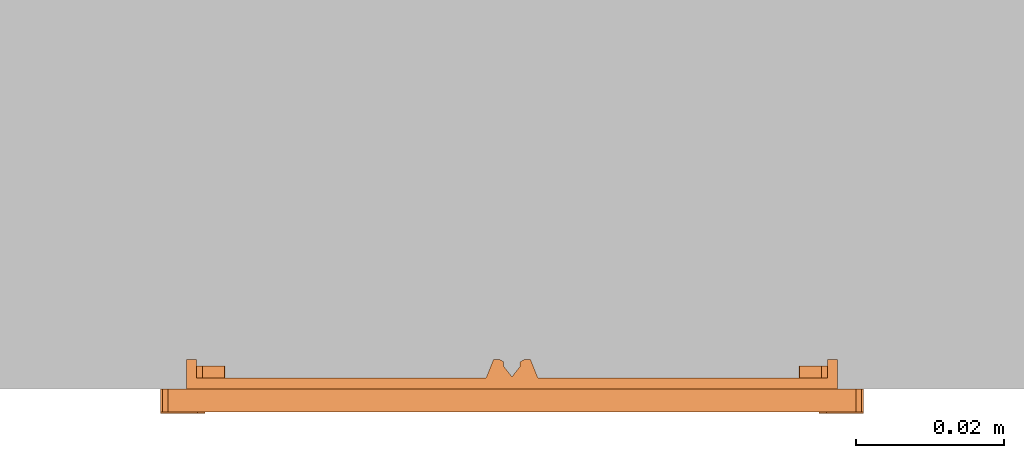
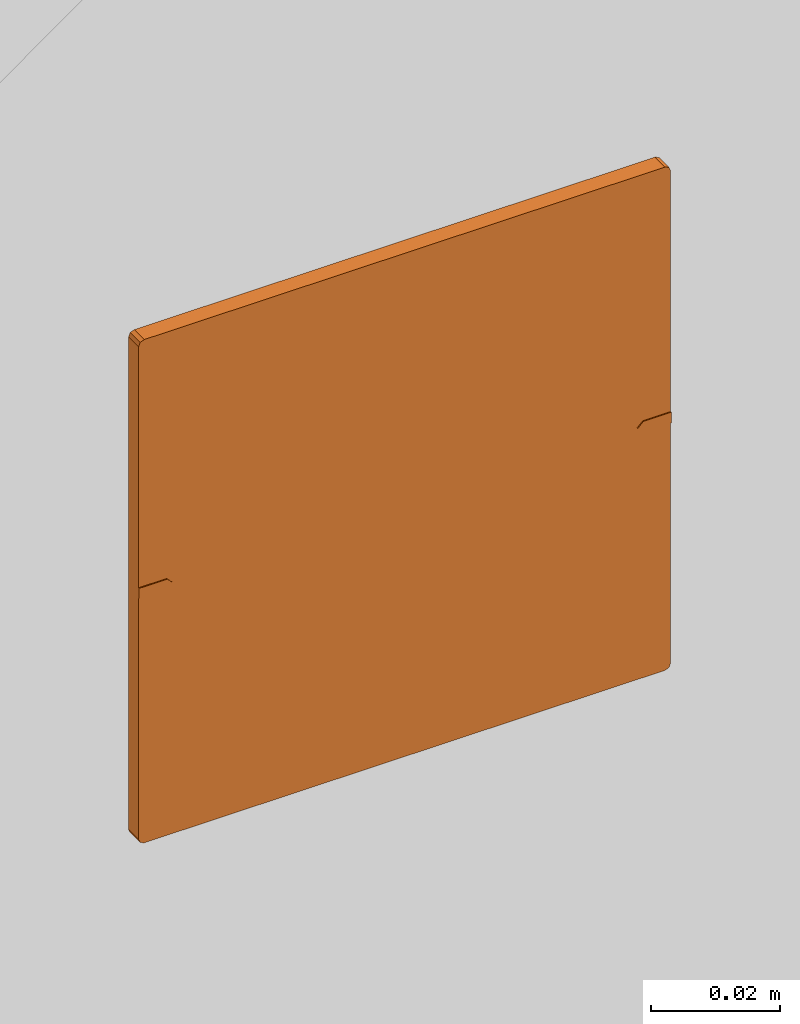
# One storey, part 2 of 2: 1 proxy.
"""IFC2X3 building model written with IfcOpenShell, lengths in metres."""

from ifc_helpers import new_model, entity, si_unit, converted_unit, derived_unit, direction, frame, origin, place, context, subcontext, project, spatial, faceted_brep, source, transform, mapped, material, type_object, type_shapes, element, save


model = new_model("IFC2X3")

# Units and contexts
model_context = context("Model", 3, precision=1e-05, world=origin(), true_north=direction((6.12303176911189e-17, 1.0)))
body_context = subcontext(model_context, "Body", "Model", "MODEL_VIEW")
ifc_project = project(units=[si_unit("LENGTHUNIT", "METRE"), si_unit("AREAUNIT", "SQUARE_METRE"), si_unit("VOLUMEUNIT", "CUBIC_METRE"), converted_unit("PLANEANGLEUNIT", "DEGREE", entity("IfcRatioMeasure", 0.0174532925199433), si_unit("PLANEANGLEUNIT", "RADIAN"), dimensions=[0, 0, 0, 0, 0, 0, 0]), si_unit("MASSUNIT", "GRAM", prefix="KILO"), si_unit("TIMEUNIT", "SECOND"), si_unit("FREQUENCYUNIT", "HERTZ"), si_unit("THERMODYNAMICTEMPERATUREUNIT", "DEGREE_CELSIUS"), derived_unit("THERMALTRANSMITTANCEUNIT", [(si_unit("MASSUNIT", "GRAM", prefix="KILO"), 1), (si_unit("THERMODYNAMICTEMPERATUREUNIT", "KELVIN"), -1), (si_unit("TIMEUNIT", "SECOND"), -3)]), derived_unit("VOLUMETRICFLOWRATEUNIT", [(si_unit("LENGTHUNIT", "METRE"), 3), (si_unit("TIMEUNIT", "SECOND"), -1)]), si_unit("ELECTRICCURRENTUNIT", "AMPERE"), si_unit("ELECTRICVOLTAGEUNIT", "VOLT"), si_unit("POWERUNIT", "WATT"), si_unit("FORCEUNIT", "NEWTON", prefix="KILO"), si_unit("ILLUMINANCEUNIT", "LUX"), si_unit("LUMINOUSFLUXUNIT", "LUMEN"), si_unit("LUMINOUSINTENSITYUNIT", "CANDELA"), derived_unit("USERDEFINED", [(si_unit("MASSUNIT", "GRAM", prefix="KILO"), -1), (si_unit("LENGTHUNIT", "METRE"), -2), (si_unit("TIMEUNIT", "SECOND"), 3), (si_unit("LUMINOUSFLUXUNIT", "LUMEN"), 1)]), derived_unit("LINEARVELOCITYUNIT", [(si_unit("LENGTHUNIT", "METRE"), 1), (si_unit("TIMEUNIT", "SECOND"), -1)]), si_unit("PRESSUREUNIT", "PASCAL"), derived_unit("USERDEFINED", [(si_unit("LENGTHUNIT", "METRE"), -2), (si_unit("MASSUNIT", "GRAM", prefix="KILO"), 1), (si_unit("TIMEUNIT", "SECOND"), -2)])], contexts=[model_context])

# Site, building, storey
site_placement = place(None, origin())
site = spatial("IfcSite", under=ifc_project, at=site_placement, CompositionType="ELEMENT")
building_placement = place(site_placement, origin())
building = spatial("IfcBuilding", under=site, at=building_placement, CompositionType="ELEMENT")
storey_placement = place(building_placement, origin())
storey = spatial("IfcBuildingStorey", under=building, at=storey_placement, Name="Ebene 0", CompositionType="ELEMENT", Elevation=0.0)

# Proxy
ifc_material = material(Name="White")
building_element_proxy_type = type_object("IfcBuildingElementProxyType", Name="1f 4 TS4 Edelstahl", PredefinedType="NOTDEFINED", material=ifc_material)
shared_shape = source(origin(), body_context, "Body", "Brep", [
    faceted_brep([(-0.0414999999999813, 0.0, 0.0), (-0.0424999999999813, -0.00100000000002529, 0.0), (-0.0474999999999813, -0.00100000000002529, 0.0), (-0.0474999999999813, 0.000999999999974714, 0.0), (-0.0424999999999813, 0.000999999999974713, 0.0), (-0.0474999999999813, 0.000999999999974714, 0.00329999999999813), (-0.0474999999999813, -0.00100000000002529, 0.00329999999999813), (-0.0424999999999813, -0.00100000000002529, 0.00329999999999813), (-0.0414999999999813, 0.0, 0.00329999999999813), (-0.0424999999999813, 0.000999999999974713, 0.00329999999999813)], [[[0, 1, 2, 3, 4]], [[5, 6, 7, 8, 9]], [[7, 6, 2, 1]], [[7, 1, 0, 8]], [[0, 4, 9, 8]], [[5, 9, 4, 3]], [[6, 5, 3, 2]]]),
    faceted_brep([(0.0415000000000187, 0.0, 0.00329999999999813), (0.0425000000000187, -0.00100000000002529, 0.00329999999999813), (0.0475000000000187, -0.00100000000002529, 0.00329999999999813), (0.0475000000000187, 0.000999999999974714, 0.00329999999999813), (0.0425000000000187, 0.000999999999974713, 0.00329999999999813), (0.0475000000000187, 0.000999999999974714, 0.0), (0.0475000000000187, -0.00100000000002529, 0.0), (0.0425000000000187, -0.00100000000002529, 0.0), (0.0415000000000187, 0.0, 0.0), (0.0425000000000187, 0.000999999999974713, 0.0)], [[[0, 1, 2, 3, 4]], [[5, 6, 7, 8, 9]], [[3, 2, 6, 5]], [[4, 3, 5, 9]], [[4, 9, 8, 0]], [[8, 7, 1, 0]], [[2, 1, 7, 6]]]),
    faceted_brep([(0.0475000000000187, 0.000999999999974714, 0.00309999999999813), (0.0475000000000187, 0.0464999999999747, 0.00309999999999813), (0.0472071067812052, 0.0472071067811613, 0.00309999999999813), (0.0465000000000187, 0.0474999999999747, 0.00309999999999813), (-0.0464999999999813, 0.0474999999999747, 0.00309999999999813), (-0.0472071067811679, 0.0472071067811613, 0.00309999999999813), (-0.0474999999999813, 0.0464999999999747, 0.00309999999999813), (-0.0474999999999813, 0.000999999999974714, 0.00309999999999813), (-0.0424999999999813, 0.000999999999974714, 0.00309999999999813), (-0.0414999999999813, 0.0, 0.00309999999999813), (-0.0424999999999813, -0.00100000000002529, 0.00309999999999813), (-0.0474999999999813, -0.00100000000002529, 0.00309999999999813), (-0.0474999999999813, -0.0465000000000253, 0.00309999999999813), (-0.0472071067811679, -0.0472071067812118, 0.00309999999999813), (-0.0464999999999813, -0.0475000000000253, 0.00309999999999813), (0.0465000000000187, -0.0475000000000253, 0.00309999999999813), (0.0472071067812052, -0.0472071067812119, 0.00309999999999813), (0.0475000000000188, -0.0465000000000253, 0.00309999999999813), (0.0475000000000187, -0.00100000000002529, 0.00309999999999813), (0.0425000000000187, -0.00100000000002529, 0.00309999999999813), (0.0415000000000187, 0.0, 0.00309999999999813), (0.0425000000000187, 0.000999999999974714, 0.00309999999999813), (-0.0474999999999813, 0.000999999999974714, 0.0), (-0.0474999999999813, 0.0464999999999747, 0.0), (-0.0472071067811679, 0.0472071067811613, 0.0), (-0.0464999999999813, 0.0474999999999747, 0.0), (0.0465000000000187, 0.0474999999999747, 0.0), (0.0472071067812052, 0.0472071067811613, 0.0), (0.0475000000000187, 0.0464999999999747, 0.0), (0.0475000000000187, 0.000999999999974714, 0.0), (0.0425000000000187, 0.000999999999974714, 0.0), (0.0415000000000187, 0.0, 0.0), (0.0425000000000187, -0.00100000000002529, 0.0), (0.0475000000000187, -0.00100000000002529, 0.0), (0.0475000000000187, -0.0465000000000253, 0.0), (0.0472071067812052, -0.0472071067812119, 0.0), (0.0465000000000187, -0.0475000000000253, 0.0), (-0.0464999999999813, -0.0475000000000253, 0.0), (-0.0472071067811679, -0.0472071067812118, 0.0), (-0.0474999999999813, -0.0465000000000253, 0.0), (-0.0474999999999813, -0.00100000000002529, 0.0), (-0.0424999999999813, -0.00100000000002529, 0.0), (-0.0414999999999813, 0.0, 0.0), (-0.0424999999999813, 0.000999999999974714, 0.0)], [[[0, 1, 2, 3, 4, 5, 6, 7, 8, 9, 10, 11, 12, 13, 14, 15, 16, 17, 18, 19, 20, 21]], [[22, 23, 24, 25, 26, 27, 28, 29, 30, 31, 32, 33, 34, 35, 36, 37, 38, 39, 40, 41, 42, 43]], [[4, 3, 26, 25]], [[4, 25, 24, 5]], [[24, 23, 6, 5]], [[7, 6, 23, 22]], [[12, 11, 40, 39]], [[12, 39, 38, 13]], [[38, 37, 14, 13]], [[15, 14, 37, 36]], [[15, 36, 35, 16]], [[35, 34, 17, 16]], [[1, 28, 27, 2]], [[27, 26, 3, 2]], [[8, 7, 22, 43]], [[0, 21, 30, 29]], [[43, 42, 9, 8]], [[41, 10, 9, 42]], [[11, 10, 41, 40]], [[19, 18, 33, 32]], [[18, 17, 34, 33]], [[1, 0, 29, 28]], [[32, 31, 20, 19]], [[30, 21, 20, 31]]]),
    faceted_brep([(0.0405700030454818, 0.00188327647116063, -0.00150000000000187), (0.0394152841158834, 0.00384738323790948, -0.00150000000000187), (0.0396693466398987, 0.00538018883192929, -0.00150000000000187), (0.0412228887906423, 0.00540358842658813, -0.00150000000000187), (0.0429375838166535, 0.00401505577272542, -0.00150000000000187), (-0.0426552669850686, -0.0409075747265832, -0.00150000000000187), (-0.0439761825973736, -0.0409075747265832, -0.00150000000000187), (-0.0439761825973736, -0.00446077462911593, -0.00150000000000187), (-0.0418522091816548, -0.00618073438809566, -0.00150000000000187), (-0.0388839241228238, -0.00601365327271754, -0.00150000000000187), (-0.038762804972744, -0.00304313775498671, -0.00150000000000187), (-0.038762804972744, 0.00304313775493612, -0.00150000000000187), (-0.0388839241228238, 0.00601365327266693, -0.00150000000000187), (-0.0418522091816548, 0.00618073438804511, -0.00150000000000187), (-0.0439761825973736, 0.00446077462906535, -0.00150000000000187), (-0.0439761825973736, 0.0409075747265326, -0.00150000000000187), (-0.0426552669850686, 0.0409075747265326, -0.00150000000000187), (-0.0426552669850686, 0.0441884598486688, -0.00150000000000187), (0.042655266985106, 0.0441884598486688, -0.00150000000000187), (0.042655266985106, 0.0409075747265326, -0.00150000000000187), (0.043976182597411, 0.0409075747265326, -0.00150000000000187), (0.043976182597411, 0.00446077462906534, -0.00150000000000187), (0.0418522091816922, 0.00618073438804509, -0.00150000000000187), (0.0388839241228612, 0.00601365327266697, -0.00150000000000187), (0.0387628049727813, 0.00304313775493616, -0.00150000000000187), (0.0387628049727813, -0.00304313775498669, -0.00150000000000187), (0.0388839241228611, -0.0060136532727175, -0.00150000000000187), (0.0418522091816922, -0.00618073438809568, -0.00150000000000187), (0.043976182597411, -0.00446077462911591, -0.00150000000000187), (0.043976182597411, -0.0409075747265832, -0.00150000000000187), (0.042655266985106, -0.0409075747265832, -0.00150000000000187), (0.042655266985106, -0.0441884598487194, -0.00150000000000187), (-0.0426552669850686, -0.0441884598487194, -0.00150000000000187), (0.0412228887906423, -0.00540358842663871, -0.00150000000000187), (0.0396693466398987, -0.00538018883197987, -0.00150000000000187), (0.0394152841158834, -0.00384738323796005, -0.00150000000000187), (0.0405700030454818, -0.0018832764712112, -0.00150000000000187), (0.0429375838166535, -0.00401505577277598, -0.00150000000000187), (-0.0394152841158461, 0.00384738323790948, -0.00150000000000187), (-0.0405700030454445, 0.00188327647116063, -0.00150000000000187), (-0.0429375838166161, 0.0040150557727254, -0.00150000000000187), (-0.041222888790605, 0.00540358842658813, -0.00150000000000187), (-0.0396693466398613, 0.00538018883192931, -0.00150000000000187), (-0.0396693466398613, -0.00538018883197987, -0.00150000000000187), (-0.041222888790605, -0.00540358842663871, -0.00150000000000187), (-0.0429375838166161, -0.00401505577277599, -0.00150000000000187), (-0.0405700030454445, -0.0018832764712112, -0.00150000000000187), (-0.0394152841158461, -0.00384738323796005, -0.00150000000000187), (0.042655266985106, -0.0441884598487194, -0.00400000000000188), (0.042655266985106, -0.0409075747265832, -0.00400000000000188), (0.043976182597411, -0.0409075747265832, -0.00400000000000188), (0.043976182597411, -0.0441884598487194, -0.00400000000000188), (0.042655266985106, 0.0409075747265326, -0.00400000000000188), (0.042655266985106, 0.0441884598486688, -0.00400000000000188), (0.043976182597411, 0.0441884598486688, -0.00400000000000188), (0.043976182597411, 0.0409075747265326, -0.00400000000000188), (-0.0439761825973736, 0.0409075747265326, -0.00400000000000188), (-0.0439761825973736, 0.0441884598486688, -0.00400000000000188), (-0.0426552669850686, 0.0441884598486688, -0.00400000000000188), (-0.0426552669850686, 0.0409075747265326, -0.00400000000000188), (-0.0439761825973736, -0.0441884598487194, -0.00400000000000188), (-0.0439761825973736, -0.0409075747265832, -0.00400000000000188), (-0.0426552669850686, -0.0409075747265832, -0.00400000000000188), (-0.0426552669850686, -0.0441884598487194, -0.00400000000000188), (-0.0418522091816548, -0.00618073438809568, -0.00310000000000187), (-0.041222888790605, -0.00540358842663871, -0.00310000000000187), (-0.0396693466398613, -0.00538018883197987, -0.00310000000000187), (-0.0429375838166161, -0.00401505577277598, -0.00310000000000187), (-0.0439761825973736, -0.00446077462911592, -0.00310000000000187), (-0.0388839241228238, -0.00601365327271752, -0.00310000000000187), (-0.0429375838166161, 0.00401505577272541, -0.00310000000000187), (-0.0439761825973736, 0.00446077462906536, -0.00310000000000187), (-0.0418522091816548, 0.00618073438804511, -0.00310000000000187), (-0.041222888790605, 0.00540358842658814, -0.00310000000000187), (-0.0396693466398613, 0.0053801888319293, -0.00310000000000187), (-0.0388839241228238, 0.00601365327266694, -0.00310000000000187), (-0.0394152841158461, 0.00384738323790948, -0.00310000000000187), (-0.038762804972744, 0.00304313775493616, -0.00310000000000187), (-0.0405700030454445, 0.00188327647116062, -0.00310000000000187), (-0.038762804972744, -0.00304313775498671, -0.00310000000000187), (-0.0405700030454445, -0.0018832764712112, -0.00310000000000187), (-0.0394152841158461, -0.00384738323796005, -0.00310000000000187), (0.0388839241228611, -0.00601365327271752, -0.00310000000000187), (0.0396693466398987, -0.00538018883197987, -0.00310000000000187), (0.0418522091816922, -0.00618073438809568, -0.00310000000000187), (0.0394152841158834, -0.00384738323796005, -0.00310000000000187), (0.0387628049727813, -0.00304313775498671, -0.00310000000000187), (0.0405700030454818, -0.0018832764712112, -0.00310000000000187), (0.0405700030454818, 0.00188327647116063, -0.00310000000000187), (0.0387628049727813, 0.00304313775493616, -0.00310000000000187), (0.0394152841158834, 0.00384738323790948, -0.00310000000000187), (0.0388839241228612, 0.00601365327266696, -0.00310000000000187), (0.0396693466398987, 0.00538018883192929, -0.00310000000000187), (0.0418522091816922, 0.00618073438804511, -0.00310000000000187), (0.0412228887906423, 0.00540358842658814, -0.00310000000000187), (0.0429375838166535, 0.00401505577272541, -0.00310000000000187), (0.043976182597411, 0.00446077462906536, -0.00310000000000187), (0.043976182597411, -0.00446077462911592, -0.00310000000000187), (0.0429375838166535, -0.00401505577277598, -0.00310000000000187), (0.0412228887906423, -0.00540358842663871, -0.00310000000000187), (0.043976182597411, 0.0441884598486688, 0.0), (-0.0439761825973736, 0.0441884598486688, 0.0), (-0.0439761825973736, -0.0441884598487194, 0.0), (0.043976182597411, -0.0441884598487194, 0.0)], [[[0, 1, 2, 3, 4]], [[5, 6, 7, 8, 9, 10, 11, 12, 13, 14, 15, 16, 17, 18, 19, 20, 21, 22, 23, 24, 25, 26, 27, 28, 29, 30, 31, 32]], [[33, 34, 35, 36, 37]], [[38, 39, 40, 41, 42]], [[43, 44, 45, 46, 47]], [[48, 49, 50, 51]], [[52, 53, 54, 55]], [[56, 57, 58, 59]], [[60, 61, 62, 63]], [[64, 65, 66]], [[65, 64, 67]], [[68, 67, 64]], [[66, 69, 64]], [[67, 68, 70]], [[70, 68, 71]], [[70, 71, 72]], [[72, 73, 70]], [[73, 72, 74]], [[75, 74, 72]], [[76, 74, 75]], [[76, 75, 77]], [[77, 78, 76]], [[78, 77, 79]], [[79, 80, 78]], [[81, 80, 79]], [[81, 79, 69]], [[69, 66, 81]], [[80, 67, 70]], [[70, 78, 80]], [[64, 65, 66]], [[65, 64, 67]], [[68, 67, 64]], [[66, 69, 64]], [[67, 68, 70]], [[70, 68, 71]], [[70, 71, 72]], [[72, 73, 70]], [[73, 72, 74]], [[75, 74, 72]], [[76, 74, 75]], [[76, 75, 77]], [[77, 78, 76]], [[78, 77, 79]], [[79, 80, 78]], [[81, 80, 79]], [[81, 79, 69]], [[69, 66, 81]], [[80, 67, 70]], [[70, 78, 80]], [[82, 83, 84]], [[83, 82, 85]], [[86, 85, 82]], [[85, 86, 87]], [[86, 88, 87]], [[89, 88, 86]], [[89, 90, 88]], [[90, 89, 91]], [[91, 92, 90]], [[92, 91, 93]], [[93, 94, 92]], [[93, 95, 94]], [[95, 93, 96]], [[95, 96, 97]], [[95, 97, 98]], [[98, 97, 84]], [[84, 99, 98]], [[99, 84, 83]], [[95, 98, 87]], [[95, 87, 88]], [[100, 101, 102, 103]], [[101, 57, 56, 15, 14, 71, 68, 7, 6, 61, 60, 102]], [[102, 60, 63, 32, 31, 48, 51, 103]], [[103, 51, 50, 29, 28, 97, 96, 21, 20, 55, 54, 100]], [[100, 54, 53, 18, 17, 58, 57, 101]], [[16, 15, 56, 59]], [[20, 19, 52, 55]], [[17, 16, 59, 58]], [[5, 32, 63, 62]], [[19, 18, 53, 52]], [[31, 30, 49, 48]], [[6, 5, 62, 61]], [[30, 29, 50, 49]], [[8, 7, 68, 64]], [[8, 64, 69, 9]], [[69, 79, 10, 9]], [[11, 10, 79, 77]], [[11, 77, 75, 12]], [[75, 72, 13, 12]], [[14, 13, 72, 71]], [[74, 42, 41, 73]], [[76, 38, 42, 74]], [[39, 38, 76, 78]], [[40, 39, 78, 70]], [[41, 40, 70, 73]], [[45, 44, 65, 67]], [[46, 45, 67, 80]], [[47, 46, 80, 81]], [[66, 43, 47, 81]], [[65, 44, 43, 66]], [[22, 21, 96, 93]], [[93, 91, 23, 22]], [[23, 91, 89, 24]], [[25, 24, 89, 86]], [[86, 82, 26, 25]], [[26, 82, 84, 27]], [[28, 27, 84, 97]], [[4, 3, 94, 95]], [[0, 4, 95, 88]], [[1, 0, 88, 90]], [[92, 2, 1, 90]], [[94, 3, 2, 92]], [[83, 34, 33, 99]], [[85, 35, 34, 83]], [[36, 35, 85, 87]], [[37, 36, 87, 98]], [[33, 37, 98, 99]]]),
    faceted_brep([(0.00250000000001867, 0.0441989549366141, -0.00400000000000187), (0.00163920496297101, 0.0441989549366141, -0.00400000000000187), (0.00111462194137819, 0.0441989549366141, -0.00369427185540776), (0.00109935595354812, 0.0441989549366141, -0.00308714597451479), (-1.13481550753538e-05, 0.0441989549366141, -0.00166585136014561), (-0.00112205226369883, 0.0441989549366141, -0.00308714597451479), (-0.00111462194134082, 0.0441989549366141, -0.00369427185540776), (-0.00163920496293365, 0.0441989549366141, -0.00400000000000187), (-0.00249999999998131, 0.0441989549366141, -0.00400000000000187), (-0.00349999999998132, 0.0441989549366141, -0.00150000000000187), (0.00350000000001868, 0.0441989549366141, -0.00150000000000187), (-0.00349999999998132, 0.0419845832827041, -0.00150000000000187), (-0.00249999999998131, 0.0419845832827041, -0.00400000000000187), (-0.00163920496293365, 0.0419845832827041, -0.00400000000000187), (-0.00111462194134082, 0.0419845832827041, -0.00369427185540776), (-0.00112205226369884, 0.0419845832827041, -0.00308714597451478), (-1.13481550753538e-05, 0.0419845832827041, -0.00166585136014561), (0.00112205226373619, 0.0419845832827041, -0.00308714597451479), (0.00111462194137819, 0.0419845832827041, -0.00369427185540776), (0.00163920496297101, 0.0419845832827041, -0.00400000000000187), (0.00250000000001867, 0.0419845832827041, -0.00400000000000187), (0.00350000000001868, 0.0419845832827041, -0.00150000000000187)], [[[0, 1, 2, 3, 4, 5, 6, 7, 8, 9, 10]], [[11, 12, 13, 14, 15, 16, 17, 18, 19, 20, 21]], [[8, 7, 13, 12]], [[1, 0, 20, 19]], [[5, 15, 14, 6]], [[14, 13, 7, 6]], [[17, 4, 3]], [[16, 4, 17]], [[15, 5, 4, 16]], [[1, 19, 18, 2]], [[17, 3, 2]], [[17, 2, 18]], [[0, 10, 21, 20]], [[10, 9, 11, 21]], [[9, 8, 12, 11]]]),
    faceted_brep([(-0.00249999999998131, -0.0441989549366647, -0.00400000000000187), (-0.00163920496293365, -0.0441989549366647, -0.00400000000000187), (-0.00111462194134083, -0.0441989549366647, -0.00369427185540776), (-0.00112205226369883, -0.0441989549366647, -0.00308714597451479), (-1.13481550753623e-05, -0.0441989549366647, -0.00166585136014561), (0.00112205226373619, -0.0441989549366647, -0.00308714597451479), (0.00111462194137818, -0.0441989549366647, -0.00369427185540776), (0.00163920496297101, -0.0441989549366647, -0.00400000000000187), (0.00250000000001867, -0.0441989549366647, -0.00400000000000187), (0.00350000000001868, -0.0441989549366647, -0.00150000000000187), (-0.00349999999998132, -0.0441989549366647, -0.00150000000000187), (0.00250000000001867, -0.0419845832827547, -0.00400000000000187), (0.00163920496297101, -0.0419845832827547, -0.00400000000000187), (0.00111462194137818, -0.0419845832827547, -0.00369427185540776), (0.00109935595354812, -0.0419845832827547, -0.00308714597451478), (-1.13481550753623e-05, -0.0419845832827547, -0.00166585136014561), (-0.00112205226369883, -0.0419845832827547, -0.00308714597451479), (-0.00111462194134083, -0.0419845832827547, -0.00369427185540776), (-0.00163920496293365, -0.0419845832827547, -0.00400000000000187), (-0.00249999999998131, -0.0419845832827547, -0.00400000000000187), (-0.00349999999998132, -0.0419845832827547, -0.00150000000000187), (0.00350000000001868, -0.0419845832827547, -0.00150000000000187)], [[[0, 1, 2, 3, 4, 5, 6, 7, 8, 9, 10]], [[11, 12, 13, 14, 15, 16, 17, 18, 19, 20, 21]], [[1, 0, 19, 18]], [[8, 7, 12, 11]], [[1, 18, 17, 2]], [[17, 16, 3, 2]], [[16, 15, 4, 3]], [[15, 14, 4]], [[5, 4, 14]], [[5, 14, 6]], [[6, 14, 13]], [[13, 12, 7, 6]], [[9, 8, 11, 21]], [[10, 9, 21, 20]], [[0, 10, 20, 19]]]),
])
type_shapes(building_element_proxy_type, [shared_shape])
proxy_placement = place(storey_placement, frame((-7.3192018927039, -2.38240134987377, 1.45785155289665), z_axis=(0.0, -1.0, 0.0), x_axis=(1.0, 0.0, 0.0)))
element("IfcBuildingElementProxy", 1, at=proxy_placement, inside=storey, type_object=building_element_proxy_type, material=ifc_material, Name="1f 4 TS4 Edelstahl", ObjectType="1f 4 TS4 Edelstahl", context=body_context, shape_type="MappedRepresentation", body=[
    mapped(shared_shape, transform((0.0, 0.0, 0.0), scale=1.0)),
])

save(model, "model.ifc")
